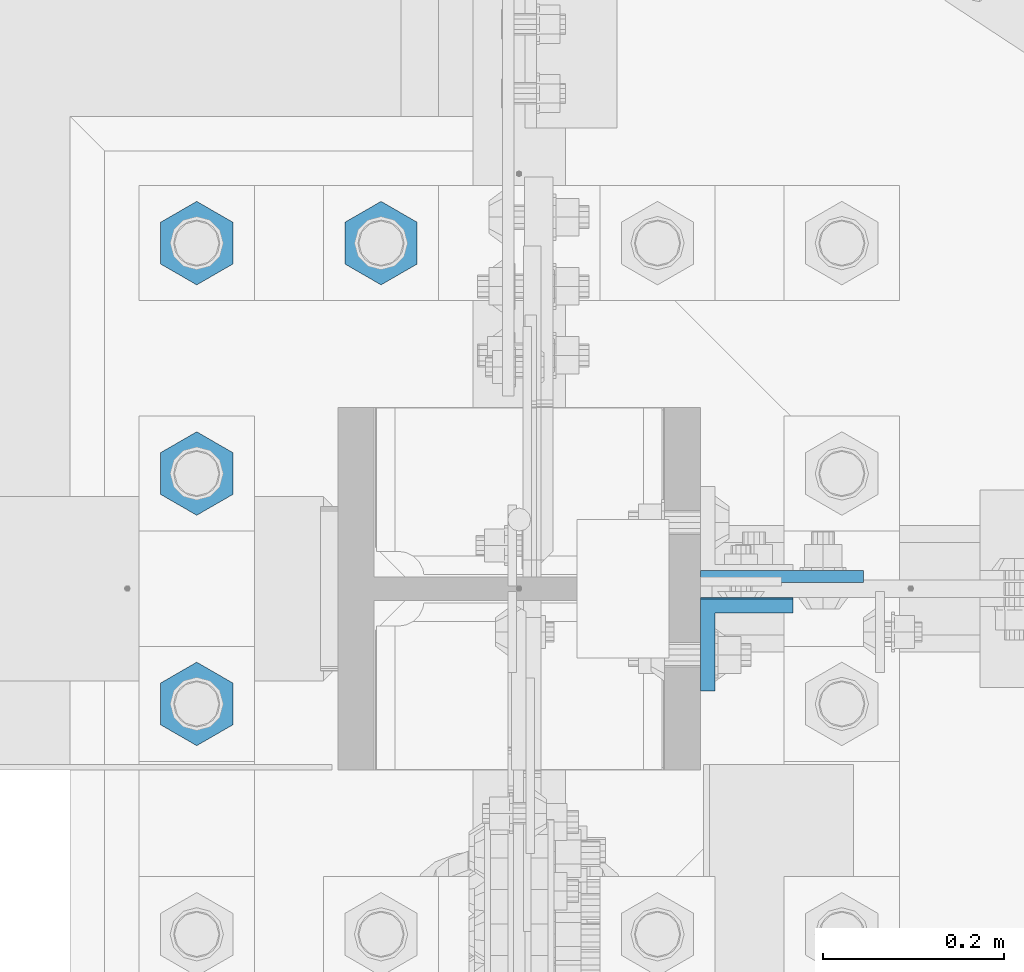
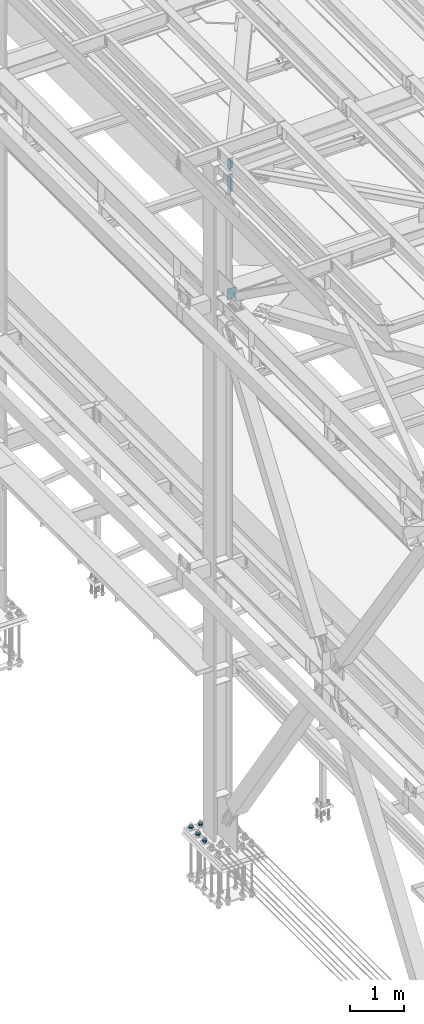
# One storey, part 1527 of 3843: 7 columns, 3 elements without a shape of their own.
"""IFC2X3 building model written with IfcOpenShell, lengths in millimetres."""

from ifc_helpers import new_model, si_unit, frame, origin_with_axes, place, context, subcontext, project, spatial, faceted_brep, material, type_object, element, aggregate, save


model = new_model("IFC2X3")

# Units and contexts
model_context = context("Model", 3, precision=1e-05, world=origin_with_axes())
body_context = subcontext(model_context, "Body", "Model", "MODEL_VIEW")
ifc_project = project(units=[si_unit("LENGTHUNIT", "METRE", prefix="MILLI"), si_unit("AREAUNIT", "SQUARE_METRE"), si_unit("VOLUMEUNIT", "CUBIC_METRE"), si_unit("MASSUNIT", "GRAM", prefix="KILO"), si_unit("TIMEUNIT", "SECOND"), si_unit("PLANEANGLEUNIT", "RADIAN"), si_unit("SOLIDANGLEUNIT", "STERADIAN"), si_unit("THERMODYNAMICTEMPERATUREUNIT", "DEGREE_CELSIUS"), si_unit("LUMINOUSINTENSITYUNIT", "LUMEN")], contexts=[model_context])

# Site, building, storey
site_placement = place(None, origin_with_axes())
site = spatial("IfcSite", under=ifc_project, at=site_placement, CompositionType="ELEMENT")
building_placement = place(site_placement, origin_with_axes())
building = spatial("IfcBuilding", under=site, at=building_placement, Name="Undefined", CompositionType="ELEMENT")
storey_placement = place(building_placement, origin_with_axes())
storey = spatial("IfcBuildingStorey", under=building, at=storey_placement, Name="Undefined", CompositionType="ELEMENT", Elevation=0.0)

# Assembly, columns
assembly_1_placement = place(storey_placement, origin_with_axes())
assembly_1 = element("IfcElementAssembly", 1, at=assembly_1_placement, inside=storey, Name="BEAM", AssemblyPlace="NOTDEFINED", PredefinedType="RIGID_FRAME")
ifc_material = material(Name="STEEL/A572-50")
column_type_1 = type_object("IfcColumnType", Name="L4X4X5/8", PredefinedType="NOTDEFINED")
column_1_placement = place(assembly_1_placement, frame((36826.8250000141, 58853.3879995346, 45113.5459635213), z_axis=(0.0, -1.0, 0.0), x_axis=(0.0, 0.0, 1.0)))
column_1 = element("IfcColumn", 2, at=column_1_placement, type_object=column_type_1, material=ifc_material, Name="ANGLE", ObjectType="L4X4X5/8", context=body_context, shape_type="Brep", body=[
    faceted_brep([(0.0, 50.8000000000029, -50.8000000000029), (0.0, 50.8000000000029, 50.8000000000029), (228.600164820818, 50.8000000000029, 50.8000000000029), (228.600164820818, 50.8000000000029, -50.8000000000029), (0.0, 34.9250000000029, 50.8000000000029), (228.600164820818, 34.9250000000029, 50.8000000000029), (0.0, 34.9250000000029, -34.9250000000029), (228.600164820818, 34.9250000000029, -34.9250000000029), (0.0, -50.8000000000029, -34.9250000000029), (228.600164820818, -50.8000000000029, -34.9250000000029), (0.0, -50.8000000000029, -50.8000000000029), (228.600164820818, -50.8000000000029, -50.8000000000029)], [[[0, 1, 2, 3]], [[1, 4, 5, 2]], [[4, 6, 7, 5]], [[6, 8, 9, 7]], [[8, 10, 11, 9]], [[10, 0, 3, 11]], [[5, 7, 9, 11, 3, 2]], [[10, 8, 6, 4, 1, 0]]]),
])
column_2_placement = place(assembly_1_placement, frame((36826.825, 58854.9750003815, 44572.4922976162), z_axis=(0.0, -1.0, 0.0), x_axis=(0.0, 0.0, 1.0)))
column_2 = element("IfcColumn", 3, at=column_2_placement, type_object=column_type_1, material=ifc_material, Name="ANGLE", ObjectType="L4X4X5/8", context=body_context, shape_type="Brep", body=[
    faceted_brep([(0.0, 50.8000000000029, -50.8000000000029), (0.0, 50.8000000000029, 50.8000000000029), (406.399999999841, 50.799999998344, 50.8000000000029), (406.399999999841, 50.799999998344, -50.8000000000029), (0.0, 34.9250000000029, 50.8000000000029), (406.399999999892, 34.924999998344, 50.8000000000029), (0.0, 34.9250000000029, -34.9250000000029), (406.399999999892, 34.924999998344, -34.9250000000029), (0.0, -50.8000000000029, -34.9250000000029), (406.400000000162, -50.8000000016473, -34.9250000000029), (0.0, -50.8000000000029, -50.8000000000029), (406.400000000162, -50.8000000016473, -50.8000000000029)], [[[0, 1, 2, 3]], [[1, 4, 5, 2]], [[4, 6, 7, 5]], [[6, 8, 9, 7]], [[8, 10, 11, 9]], [[10, 0, 3, 11]], [[5, 7, 9, 11, 3, 2]], [[10, 8, 6, 4, 1, 0]]]),
])
aggregate(assembly_1, [column_1, column_2])

# Assembly, column
assembly_2_placement = place(storey_placement, origin_with_axes())
assembly_2 = element("IfcElementAssembly", 4, at=assembly_2_placement, inside=storey, Name="COLUMN", AssemblyPlace="NOTDEFINED", PredefinedType="RIGID_FRAME")
column_type_2 = type_object("IfcColumnType", PredefinedType="NOTDEFINED")
column_3_placement = place(assembly_2_placement, frame((36865.7105, 58928.79375, 42133.8586575673), z_axis=(-1.0, 0.0, 0.0), x_axis=(0.0, 0.0, 1.0)))
column_3 = element("IfcColumn", 5, at=column_3_placement, type_object=column_type_2, material=ifc_material, Name="PLATE", context=body_context, shape_type="Brep", body=[
    faceted_brep([(0.0, 6.34999999999854, -89.6854999999996), (0.0, 6.34999999999854, 89.6854999999996), (241.299999999996, 6.34999999999854, 89.6854999999996), (241.299999999996, 6.34999999999854, -89.6854999999996), (0.0, -6.34999999999854, 89.6854999999996), (241.299999999996, -6.34999999999854, 89.6854999999996), (0.0, -6.34999999999854, -89.6854999999996), (241.299999999996, -6.34999999999854, -89.6854999999996)], [[[0, 1, 2, 3]], [[1, 4, 5, 2]], [[4, 6, 7, 5]], [[6, 0, 3, 7]], [[5, 7, 3, 2]], [[6, 4, 1, 0]]]),
])
aggregate(assembly_2, [column_3])

# Assembly, columns
assembly_3_placement = place(storey_placement, origin_with_axes())
assembly_3 = element("IfcElementAssembly", 6, at=assembly_3_placement, inside=storey, Name="TEMPLATE", AssemblyPlace="NOTDEFINED", PredefinedType="RIGID_FRAME")
column_type_3 = type_object("IfcColumnType", Name="2_HEAVY_HEX_NUT", PredefinedType="NOTDEFINED")
column_4_placement = place(assembly_3_placement, frame((36423.6, 59296.3, 30232.35), z_axis=(-1.0, 0.0, 0.0), x_axis=(0.0, 0.0, -1.0)))
column_4 = element("IfcColumn", 7, at=column_4_placement, type_object=column_type_3, material=ifc_material, Name="NUT", ObjectType="2_HEAVY_HEX_NUT", context=body_context, shape_type="Brep", body=[
    faceted_brep([(0.0, -46.0369987487793, 0.0), (0.0, -23.0184993743896, -39.869213104248), (50.7999999999993, -23.0184993743896, -39.869213104248), (50.7999999999993, -46.0369987487793, 0.0), (0.0, 23.0184993743896, -39.869213104248), (50.7999999999993, 23.0184993743896, -39.869213104248), (0.0, 46.0369987487793, 0.0), (50.7999999999993, 46.0369987487793, 0.0), (0.0, 23.0184993743896, 39.869213104248), (50.7999999999993, 23.0184993743896, 39.869213104248), (0.0, -23.0184993743896, 39.869213104248), (50.7999999999993, -23.0184993743896, 39.869213104248), (0.0, 0.0, 26.1940002441406), (0.0, 11.3650617044477, 23.5999013092805), (50.7999999999993, 11.3650617044477, 23.5999013092805), (50.7999999999993, 0.0, 26.1940002441406), (0.0, 20.4791109456419, 16.3316083006721), (50.7999999999993, 20.4791109456419, 16.3316083006721), (0.0, 25.5370200498292, 5.82867859874386), (50.7999999999993, 25.5370200498292, 5.82867859874386), (0.0, 25.5370200498292, -5.82867859874386), (50.7999999999993, 25.5370200498292, -5.82867859874386), (0.0, 20.4791109456419, -16.3316083006721), (50.7999999999993, 20.4791109456419, -16.3316083006721), (0.0, 11.3650617044477, -23.5999013092805), (50.7999999999993, 11.3650617044477, -23.5999013092805), (0.0, 0.0, -26.1940002441406), (50.7999999999993, 0.0, -26.1940002441406), (0.0, -11.3650617044477, -23.5999013092805), (50.7999999999993, -11.3650617044477, -23.5999013092805), (0.0, -20.4791109456419, -16.3316083006721), (50.7999999999993, -20.4791109456419, -16.3316083006721), (0.0, -25.5370200498292, -5.82867859874386), (50.7999999999993, -25.5370200498292, -5.82867859874386), (0.0, -25.5370200498292, 5.82867859874386), (50.7999999999993, -25.5370200498292, 5.82867859874386), (0.0, -20.4791109456419, 16.3316083006721), (50.7999999999993, -20.4791109456419, 16.3316083006721), (0.0, -11.3650617044477, 23.5999013092805), (50.7999999999993, -11.3650617044477, 23.5999013092805)], [[[0, 1, 2, 3]], [[1, 4, 5, 2]], [[4, 6, 7, 5]], [[6, 8, 9, 7]], [[8, 10, 11, 9]], [[10, 0, 3, 11]], [[12, 13, 14, 15]], [[13, 16, 17, 14]], [[16, 18, 19, 17]], [[18, 20, 21, 19]], [[20, 22, 23, 21]], [[22, 24, 25, 23]], [[24, 26, 27, 25]], [[26, 28, 29, 27]], [[28, 30, 31, 29]], [[30, 32, 33, 31]], [[32, 34, 35, 33]], [[34, 36, 37, 35]], [[36, 38, 39, 37]], [[38, 12, 15, 39]], [[5, 7, 9, 11, 3, 2], [17, 19, 21, 23, 25, 27, 29, 31, 33, 35, 37, 39, 15, 14]], [[10, 8, 6, 4, 1, 0], [38, 36, 34, 32, 30, 28, 26, 24, 22, 20, 18, 16, 13, 12]]]),
])
column_5_placement = place(assembly_3_placement, frame((36220.4, 58788.3, 30232.35), z_axis=(1.0, 0.0, 0.0), x_axis=(0.0, 0.0, -1.0)))
column_5 = element("IfcColumn", 8, at=column_5_placement, type_object=column_type_3, material=ifc_material, Name="NUT", ObjectType="2_HEAVY_HEX_NUT", context=body_context, shape_type="Brep", body=[
    faceted_brep([(0.0, -46.0369987487793, 0.0), (0.0, -23.0184993743896, -39.869213104248), (50.7999999999993, -23.0184993743896, -39.869213104248), (50.7999999999993, -46.0369987487793, 0.0), (0.0, 23.0184993743896, -39.869213104248), (50.7999999999993, 23.0184993743896, -39.869213104248), (0.0, 46.0369987487793, 0.0), (50.7999999999993, 46.0369987487793, 0.0), (0.0, 23.0184993743896, 39.869213104248), (50.7999999999993, 23.0184993743896, 39.869213104248), (0.0, -23.0184993743896, 39.869213104248), (50.7999999999993, -23.0184993743896, 39.869213104248), (0.0, 0.0, 26.1940002441406), (0.0, 11.3650617044477, 23.5999013092805), (50.7999999999993, 11.3650617044477, 23.5999013092805), (50.7999999999993, 0.0, 26.1940002441406), (0.0, 20.4791109456419, 16.3316083006721), (50.7999999999993, 20.4791109456419, 16.3316083006721), (0.0, 25.5370200498292, 5.82867859874386), (50.7999999999993, 25.5370200498292, 5.82867859874386), (0.0, 25.5370200498292, -5.82867859874386), (50.7999999999993, 25.5370200498292, -5.82867859874386), (0.0, 20.4791109456419, -16.3316083006721), (50.7999999999993, 20.4791109456419, -16.3316083006721), (0.0, 11.3650617044477, -23.5999013092805), (50.7999999999993, 11.3650617044477, -23.5999013092805), (0.0, 0.0, -26.1940002441406), (50.7999999999993, 0.0, -26.1940002441406), (0.0, -11.3650617044477, -23.5999013092805), (50.7999999999993, -11.3650617044477, -23.5999013092805), (0.0, -20.4791109456419, -16.3316083006721), (50.7999999999993, -20.4791109456419, -16.3316083006721), (0.0, -25.5370200498292, -5.82867859874386), (50.7999999999993, -25.5370200498292, -5.82867859874386), (0.0, -25.5370200498292, 5.82867859874386), (50.7999999999993, -25.5370200498292, 5.82867859874386), (0.0, -20.4791109456419, 16.3316083006721), (50.7999999999993, -20.4791109456419, 16.3316083006721), (0.0, -11.3650617044477, 23.5999013092805), (50.7999999999993, -11.3650617044477, 23.5999013092805)], [[[0, 1, 2, 3]], [[1, 4, 5, 2]], [[4, 6, 7, 5]], [[6, 8, 9, 7]], [[8, 10, 11, 9]], [[10, 0, 3, 11]], [[12, 13, 14, 15]], [[13, 16, 17, 14]], [[16, 18, 19, 17]], [[18, 20, 21, 19]], [[20, 22, 23, 21]], [[22, 24, 25, 23]], [[24, 26, 27, 25]], [[26, 28, 29, 27]], [[28, 30, 31, 29]], [[30, 32, 33, 31]], [[32, 34, 35, 33]], [[34, 36, 37, 35]], [[36, 38, 39, 37]], [[38, 12, 15, 39]], [[5, 7, 9, 11, 3, 2], [17, 19, 21, 23, 25, 27, 29, 31, 33, 35, 37, 39, 15, 14]], [[10, 8, 6, 4, 1, 0], [38, 36, 34, 32, 30, 28, 26, 24, 22, 20, 18, 16, 13, 12]]]),
])
column_6_placement = place(assembly_3_placement, frame((36220.4, 59042.3, 30232.35), z_axis=(-1.0, 0.0, 0.0), x_axis=(0.0, 0.0, -1.0)))
column_6 = element("IfcColumn", 9, at=column_6_placement, type_object=column_type_3, material=ifc_material, Name="NUT", ObjectType="2_HEAVY_HEX_NUT", context=body_context, shape_type="Brep", body=[
    faceted_brep([(0.0, -46.0369987487793, 0.0), (0.0, -23.0184993743896, -39.869213104248), (50.7999999999993, -23.0184993743896, -39.869213104248), (50.7999999999993, -46.0369987487793, 0.0), (0.0, 23.0184993743896, -39.869213104248), (50.7999999999993, 23.0184993743896, -39.869213104248), (0.0, 46.0369987487793, 0.0), (50.7999999999993, 46.0369987487793, 0.0), (0.0, 23.0184993743896, 39.869213104248), (50.7999999999993, 23.0184993743896, 39.869213104248), (0.0, -23.0184993743896, 39.869213104248), (50.7999999999993, -23.0184993743896, 39.869213104248), (0.0, 0.0, 26.1940002441406), (0.0, 11.3650617044477, 23.5999013092805), (50.7999999999993, 11.3650617044477, 23.5999013092805), (50.7999999999993, 0.0, 26.1940002441406), (0.0, 20.4791109456419, 16.3316083006721), (50.7999999999993, 20.4791109456419, 16.3316083006721), (0.0, 25.5370200498292, 5.82867859874386), (50.7999999999993, 25.5370200498292, 5.82867859874386), (0.0, 25.5370200498292, -5.82867859874386), (50.7999999999993, 25.5370200498292, -5.82867859874386), (0.0, 20.4791109456419, -16.3316083006721), (50.7999999999993, 20.4791109456419, -16.3316083006721), (0.0, 11.3650617044477, -23.5999013092805), (50.7999999999993, 11.3650617044477, -23.5999013092805), (0.0, 0.0, -26.1940002441406), (50.7999999999993, 0.0, -26.1940002441406), (0.0, -11.3650617044477, -23.5999013092805), (50.7999999999993, -11.3650617044477, -23.5999013092805), (0.0, -20.4791109456419, -16.3316083006721), (50.7999999999993, -20.4791109456419, -16.3316083006721), (0.0, -25.5370200498292, -5.82867859874386), (50.7999999999993, -25.5370200498292, -5.82867859874386), (0.0, -25.5370200498292, 5.82867859874386), (50.7999999999993, -25.5370200498292, 5.82867859874386), (0.0, -20.4791109456419, 16.3316083006721), (50.7999999999993, -20.4791109456419, 16.3316083006721), (0.0, -11.3650617044477, 23.5999013092805), (50.7999999999993, -11.3650617044477, 23.5999013092805)], [[[0, 1, 2, 3]], [[1, 4, 5, 2]], [[4, 6, 7, 5]], [[6, 8, 9, 7]], [[8, 10, 11, 9]], [[10, 0, 3, 11]], [[12, 13, 14, 15]], [[13, 16, 17, 14]], [[16, 18, 19, 17]], [[18, 20, 21, 19]], [[20, 22, 23, 21]], [[22, 24, 25, 23]], [[24, 26, 27, 25]], [[26, 28, 29, 27]], [[28, 30, 31, 29]], [[30, 32, 33, 31]], [[32, 34, 35, 33]], [[34, 36, 37, 35]], [[36, 38, 39, 37]], [[38, 12, 15, 39]], [[5, 7, 9, 11, 3, 2], [17, 19, 21, 23, 25, 27, 29, 31, 33, 35, 37, 39, 15, 14]], [[10, 8, 6, 4, 1, 0], [38, 36, 34, 32, 30, 28, 26, 24, 22, 20, 18, 16, 13, 12]]]),
])
column_7_placement = place(assembly_3_placement, frame((36220.4, 59296.3, 30232.35), z_axis=(-1.0, 0.0, 0.0), x_axis=(0.0, 0.0, -1.0)))
column_7 = element("IfcColumn", 10, at=column_7_placement, type_object=column_type_3, material=ifc_material, Name="NUT", ObjectType="2_HEAVY_HEX_NUT", context=body_context, shape_type="Brep", body=[
    faceted_brep([(0.0, -46.0369987487793, 0.0), (0.0, -23.0184993743896, -39.869213104248), (50.7999999999993, -23.0184993743896, -39.869213104248), (50.7999999999993, -46.0369987487793, 0.0), (0.0, 23.0184993743896, -39.869213104248), (50.7999999999993, 23.0184993743896, -39.869213104248), (0.0, 46.0369987487793, 0.0), (50.7999999999993, 46.0369987487793, 0.0), (0.0, 23.0184993743896, 39.869213104248), (50.7999999999993, 23.0184993743896, 39.869213104248), (0.0, -23.0184993743896, 39.869213104248), (50.7999999999993, -23.0184993743896, 39.869213104248), (0.0, 0.0, 26.1940002441406), (0.0, 11.3650617044477, 23.5999013092805), (50.7999999999993, 11.3650617044477, 23.5999013092805), (50.7999999999993, 0.0, 26.1940002441406), (0.0, 20.4791109456419, 16.3316083006721), (50.7999999999993, 20.4791109456419, 16.3316083006721), (0.0, 25.5370200498292, 5.82867859874386), (50.7999999999993, 25.5370200498292, 5.82867859874386), (0.0, 25.5370200498292, -5.82867859874386), (50.7999999999993, 25.5370200498292, -5.82867859874386), (0.0, 20.4791109456419, -16.3316083006721), (50.7999999999993, 20.4791109456419, -16.3316083006721), (0.0, 11.3650617044477, -23.5999013092805), (50.7999999999993, 11.3650617044477, -23.5999013092805), (0.0, 0.0, -26.1940002441406), (50.7999999999993, 0.0, -26.1940002441406), (0.0, -11.3650617044477, -23.5999013092805), (50.7999999999993, -11.3650617044477, -23.5999013092805), (0.0, -20.4791109456419, -16.3316083006721), (50.7999999999993, -20.4791109456419, -16.3316083006721), (0.0, -25.5370200498292, -5.82867859874386), (50.7999999999993, -25.5370200498292, -5.82867859874386), (0.0, -25.5370200498292, 5.82867859874386), (50.7999999999993, -25.5370200498292, 5.82867859874386), (0.0, -20.4791109456419, 16.3316083006721), (50.7999999999993, -20.4791109456419, 16.3316083006721), (0.0, -11.3650617044477, 23.5999013092805), (50.7999999999993, -11.3650617044477, 23.5999013092805)], [[[0, 1, 2, 3]], [[1, 4, 5, 2]], [[4, 6, 7, 5]], [[6, 8, 9, 7]], [[8, 10, 11, 9]], [[10, 0, 3, 11]], [[12, 13, 14, 15]], [[13, 16, 17, 14]], [[16, 18, 19, 17]], [[18, 20, 21, 19]], [[20, 22, 23, 21]], [[22, 24, 25, 23]], [[24, 26, 27, 25]], [[26, 28, 29, 27]], [[28, 30, 31, 29]], [[30, 32, 33, 31]], [[32, 34, 35, 33]], [[34, 36, 37, 35]], [[36, 38, 39, 37]], [[38, 12, 15, 39]], [[5, 7, 9, 11, 3, 2], [17, 19, 21, 23, 25, 27, 29, 31, 33, 35, 37, 39, 15, 14]], [[10, 8, 6, 4, 1, 0], [38, 36, 34, 32, 30, 28, 26, 24, 22, 20, 18, 16, 13, 12]]]),
])
aggregate(assembly_3, [column_4, column_5, column_6, column_7])

save(model, "model.ifc")
